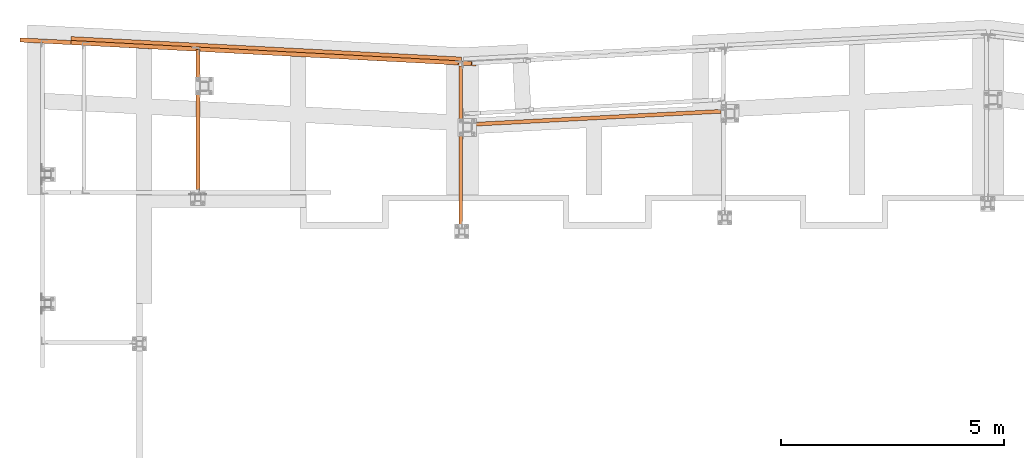
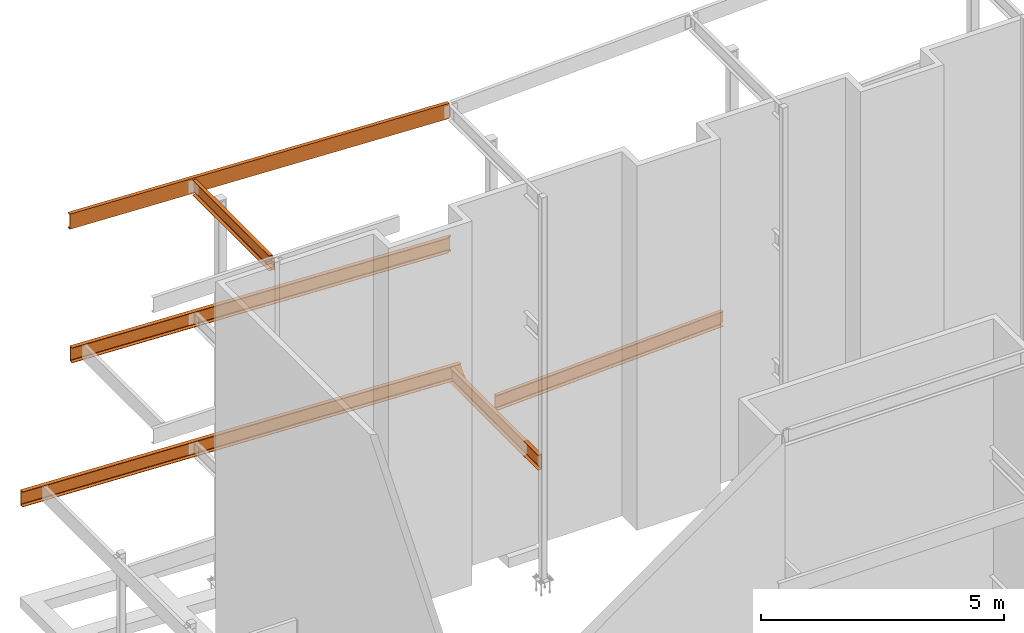
# One storey, part 14 of 89: 6 proxies.
"""IFC4 building model written with IfcOpenShell, lengths in feet."""

from ifc_helpers import new_model, entity, si_unit, converted_unit, derived_unit, direction, frame, origin, place, context, subcontext, project, spatial, faceted_brep, source, transform, mapped, material, constituent, constituent_set, type_object, type_shapes, element, save


model = new_model("IFC4")

# Units and contexts
model_context = context("Model", 3, precision=0.0001, world=origin(), true_north=direction((6.12303176911189e-17, 1.0)))
body_context = subcontext(model_context, "Body", "Model", "MODEL_VIEW")
ifc_project = project(units=[converted_unit("LENGTHUNIT", "FOOT", entity("IfcRatioMeasure", 0.3048), si_unit("LENGTHUNIT", "METRE"), dimensions=[1, 0, 0, 0, 0, 0, 0]), converted_unit("AREAUNIT", "SQUARE FOOT", entity("IfcRatioMeasure", 0.09290304), si_unit("AREAUNIT", "SQUARE_METRE"), dimensions=[2, 0, 0, 0, 0, 0, 0]), converted_unit("VOLUMEUNIT", "CUBIC FOOT", entity("IfcRatioMeasure", 0.028316846592), si_unit("VOLUMEUNIT", "CUBIC_METRE"), dimensions=[3, 0, 0, 0, 0, 0, 0]), si_unit("PLANEANGLEUNIT", "RADIAN"), si_unit("MASSUNIT", "GRAM", prefix="KILO"), derived_unit("MASSDENSITYUNIT", [(si_unit("MASSUNIT", "GRAM", prefix="KILO"), 1), (si_unit("LENGTHUNIT", "METRE"), -3)]), derived_unit("MOMENTOFINERTIAUNIT", [(si_unit("LENGTHUNIT", "METRE"), 4)]), si_unit("TIMEUNIT", "SECOND"), si_unit("FREQUENCYUNIT", "HERTZ"), si_unit("THERMODYNAMICTEMPERATUREUNIT", "DEGREE_CELSIUS"), derived_unit("THERMALTRANSMITTANCEUNIT", [(si_unit("MASSUNIT", "GRAM", prefix="KILO"), 1), (si_unit("THERMODYNAMICTEMPERATUREUNIT", "KELVIN"), -1), (si_unit("TIMEUNIT", "SECOND"), -3)]), derived_unit("VOLUMETRICFLOWRATEUNIT", [(si_unit("LENGTHUNIT", "METRE"), 3), (si_unit("TIMEUNIT", "SECOND"), -1)]), si_unit("ELECTRICCURRENTUNIT", "AMPERE"), si_unit("ELECTRICVOLTAGEUNIT", "VOLT"), si_unit("POWERUNIT", "WATT"), si_unit("FORCEUNIT", "NEWTON"), si_unit("ILLUMINANCEUNIT", "LUX"), si_unit("LUMINOUSFLUXUNIT", "LUMEN"), si_unit("LUMINOUSINTENSITYUNIT", "CANDELA"), derived_unit("USERDEFINED", [(si_unit("MASSUNIT", "GRAM", prefix="KILO"), -1), (si_unit("LENGTHUNIT", "METRE"), -2), (si_unit("TIMEUNIT", "SECOND"), 3), (si_unit("LUMINOUSFLUXUNIT", "LUMEN"), 1)]), derived_unit("LINEARVELOCITYUNIT", [(si_unit("LENGTHUNIT", "METRE"), 1), (si_unit("TIMEUNIT", "SECOND"), -1)]), si_unit("PRESSUREUNIT", "PASCAL"), derived_unit("USERDEFINED", [(si_unit("LENGTHUNIT", "METRE"), -2), (si_unit("MASSUNIT", "GRAM", prefix="KILO"), 1), (si_unit("TIMEUNIT", "SECOND"), -2)]), derived_unit("LINEARFORCEUNIT", [(si_unit("MASSUNIT", "GRAM", prefix="KILO"), 1), (si_unit("LENGTHUNIT", "METRE"), 1), (si_unit("TIMEUNIT", "SECOND"), -2), (si_unit("LENGTHUNIT", "METRE"), -1)]), derived_unit("PLANARFORCEUNIT", [(si_unit("MASSUNIT", "GRAM", prefix="KILO"), 1), (si_unit("LENGTHUNIT", "METRE"), 1), (si_unit("TIMEUNIT", "SECOND"), -2), (si_unit("LENGTHUNIT", "METRE"), -2)])], contexts=[model_context])

# Site, building, storey
site_placement = place(None, origin())
site = spatial("IfcSite", under=ifc_project, at=site_placement, CompositionType="ELEMENT")
building_placement = place(site_placement, frame((-472.238160486, -49.138065117, 0.0)))
building = spatial("IfcBuilding", under=site, at=building_placement, CompositionType="ELEMENT")
storey_placement = place(building_placement, origin())
storey = spatial("IfcBuildingStorey", under=building, at=storey_placement, Name="Level 1", CompositionType="ELEMENT", Elevation=0.0)

# Proxies
ifc_material_1 = material(Name="Color 7720", Category="Materials")
ifc_material_2 = material()
ifc_constituent_1 = constituent(ifc_material_2)
ifc_constituent_2 = constituent(ifc_material_1, Name="Color 7720", Category="Materials")
ifc_constituent_set_1 = constituent_set(constituents=[ifc_constituent_1, ifc_constituent_2])
building_element_proxy_type_1 = type_object("IfcBuildingElementProxyType", Name="B_107", PredefinedType="NOTDEFINED", material=ifc_constituent_set_1)
shared_shape_1 = source(origin(), body_context, "Body", "Brep", [
    faceted_brep([(0.0, 0.282945034847216, 1.25000000000002), (0.0, 0.282945034847216, 0.0), (0.0148285209357937, 0.0, 0.0), (0.0148285209357937, 0.0, 0.0333340558078952), (0.00405689048207591, 0.205534953036704, 0.0676357025785652), (0.00314508419060644, 0.222933253516999, 0.0738152303317055), (0.00240032733219664, 0.2371440609312, 0.0856142600983851), (0.00191364833361263, 0.246430449426384, 0.101590647231966), (0.00174453187503332, 0.249657383688714, 0.119791666666686), (0.00174453187503332, 0.249657383688714, 1.13020833333335), (0.00191364833361263, 0.246430449426384, 1.14840935276807), (0.00240032733219664, 0.2371440609312, 1.16438573990165), (0.00314508419060644, 0.222933253516999, 1.17618476966833), (0.00405689048207591, 0.205534953036704, 1.18236429742147), (0.0148285209357937, 0.0, 1.21666594419214), (0.0148285209357937, 0.0, 1.25000000000002), (18.339448172324, 1.2440747868352, 0.125000000000016), (18.339448172324, 1.2440747868352, 1.12500000000002), (18.3411927041988, 1.2107871356767, 1.12500000000002), (18.3411927041988, 1.2107871356767, 0.125000000000016), (18.219500971703, 1.23778862041752, 0.121828313854659), (18.2060018576239, 1.23708116182627, 0.112796115882787), (18.1969820379655, 1.23660845310837, 0.0992784763485677), (18.1938146985057, 1.236442459881, 0.0833333333333481), (18.1938146985057, 1.23644245988078, 0.0), (18.1938146985056, 1.2364424598843, 1.25000000000002), (18.1938146985056, 1.23644245988407, 1.16666666666668), (18.1969820379653, 1.23660845311133, 1.15072152365147), (18.2060018576237, 1.23708116182911, 1.13720388411724), (18.2195009717029, 1.23778862042025, 1.12817168614538), (18.2354242624537, 1.23862312472738, 1.12500000000002), (18.2354242624539, 1.23862312472465, 0.125000000000018), (18.1989937882445, 0.952991719775582, 0.0), (18.1989937775088, 1.1376197455063, 0.0), (18.1989937882445, 0.952991719775582, 0.0333340558078952), (18.1989937775088, 1.1376197455063, 0.0640621568246242), (18.1978715889875, 1.15903237807242, 0.067635702578583), (18.196959782696, 1.17643067855295, 0.073815230331725), (18.196668108594, 1.19066523102811, 0.0856142600983016), (18.1963589983409, 1.18789432695269, 0.0833333333332433), (18.2004385121993, 1.2001747237689, 0.101590647231944), (18.198966120559, 1.19874990194126, 0.0992784763485552), (18.218201622917, 1.20434144623516, 0.119791666666657), (18.2078113893069, 1.20255324044274, 0.112796115882778), (18.2371687943286, 1.20533547356717, 0.125000000000016), (18.2371687943286, 1.20533547356717, 1.12500000000002), (18.2212455035777, 1.20450096926015, 1.12817168614538), (18.2182016229171, 1.20434144623425, 1.13020833333335), (18.2212455035777, 1.20450096926015, 0.121828313854657), (18.2004385121993, 1.2001747237689, 1.1484093527681), (18.2078113893069, 1.20255324044274, 1.13720388411725), (18.196668108594, 1.19066523102822, 1.16438573990167), (18.198966120559, 1.19874990194126, 1.15072152365148), (18.196959782696, 1.17643067855295, 1.17618476966835), (18.1963589983409, 1.18789432695269, 1.16666666666683), (18.1978715889875, 1.15903237807242, 1.18236429742149), (18.1989937882445, 0.952991719775582, 1.21666594419212), (18.1989937775088, 1.1376197455063, 1.18593784317544), (18.1989937882445, 0.952991719775582, 1.25000000000002), (18.1989937775088, 1.1376197455063, 1.25000000000002)], [[[0, 1, 2, 3, 4, 5, 6, 7, 8, 9, 10, 11, 12, 13, 14, 15]], [[16, 17, 18, 19]], [[20, 21, 22, 23, 24, 1, 0, 25, 26, 27, 28, 29, 30, 17, 16, 31]], [[32, 2, 1, 24, 33]], [[34, 3, 2, 32]], [[35, 36, 4, 3, 34]], [[37, 5, 4, 36]], [[38, 6, 5, 37, 39]], [[40, 7, 6, 38, 41]], [[42, 8, 7, 40, 43]], [[44, 19, 18, 45, 46, 47, 9, 8, 42, 48]], [[49, 10, 9, 47, 50]], [[51, 11, 10, 49, 52]], [[53, 12, 11, 51, 54]], [[55, 13, 12, 53]], [[56, 14, 13, 55, 57]], [[58, 15, 14, 56]], [[59, 25, 0, 15, 58]], [[57, 59, 25, 26, 54, 53, 55]], [[52, 27, 26, 54, 51]], [[50, 28, 27, 52, 49]], [[46, 29, 28, 50, 47]], [[29, 46, 45, 30]], [[17, 30, 45, 18]], [[59, 58, 56, 57]], [[19, 44, 31, 16]], [[48, 20, 31, 44]], [[43, 21, 20, 48, 42]], [[41, 22, 21, 43, 40]], [[39, 23, 22, 41, 38]], [[33, 24, 23, 39, 37, 36, 35]], [[34, 32, 33, 35]]]),
])
type_shapes(building_element_proxy_type_1, [shared_shape_1])
proxy_1_placement = place(building_placement, frame((231.291038536762, 1013.05140014163, 8.35416666666665)))
element("IfcBuildingElementProxy", 1, at=proxy_1_placement, inside=storey, type_object=building_element_proxy_type_1, material=ifc_material_1, Name="B_107:B_107", ObjectType="B_107:B_107", PredefinedType="NOTDEFINED", context=body_context, shape_type="MappedRepresentation", body=[
    mapped(shared_shape_1, transform((0.0, 0.0, 0.0), scale=1.0)),
])
ifc_constituent_3 = constituent(ifc_material_2)
ifc_constituent_4 = constituent(ifc_material_1, Name="Color 7720", Category="Materials")
ifc_constituent_set_2 = constituent_set(constituents=[ifc_constituent_3, ifc_constituent_4])
building_element_proxy_type_2 = type_object("IfcBuildingElementProxyType", Name="25B1", PredefinedType="NOTDEFINED", material=ifc_constituent_set_2)
shared_shape_2 = source(origin(), body_context, "Body", "Brep", [
    faceted_brep([(0.0162241464353201, 2.06671231286009, 1.25), (0.0162241464353201, 2.06671231286009, 0.0), (0.0, 1.75713715708616, 0.0), (0.0, 1.75713715708616, 0.0333062789934004), (0.0107905097204082, 1.96303234799166, 0.0676680457191203), (0.0117017505793626, 1.98041985937664, 0.0738437414016904), (0.012446045596505, 1.9946218543347, 0.0856354543123796), (0.0129324227939946, 2.0039024841218, 0.10160193411237), (0.0131014343794789, 2.00712741728626, 0.11979166666667), (0.0131014343794789, 2.00712741728626, 1.13020833333333), (0.0129324227939946, 2.0039024841218, 1.14839806588763), (0.012446045596505, 1.9946218543347, 1.16436454568762), (0.0117017505793626, 1.98041985937664, 1.17615625859831), (0.0107905097204082, 1.96303234799166, 1.18233195428088), (0.0, 1.75713715708616, 1.2166937210066), (0.0, 1.75713715708616, 1.25), (33.1786171436809, 0.0183195129034175, 1.24999999999983), (33.1879311015114, 0.0178313890571644, 1.21669372100643), (33.2083307316719, 0.22322298729955, 1.18233195428071), (33.2109689792966, 0.240519990095095, 1.17615625859814), (33.2150107761697, 0.25454917030379, 1.16436454568747), (33.2199621108483, 0.263595801584643, 1.14839806588746), (33.225217802996, 0.266554153116999, 1.13020833333318), (33.5077764828886, 0.251745880186945, 0.119791666666794), (33.5126941518654, 0.248254365390039, 0.101601934112509), (33.516672732149, 0.23873973709658, 0.0856354543125182), (33.5192259389879, 0.224364927389274, 0.0738437414018431), (33.5200417048946, 0.206886907414855, 0.0676680457192642), (33.5188603156145, 0.000488123846139388, 0.0333062789935674), (33.5281742734449, 0.0, 0.0), (33.5443984198801, 0.309575155773928, 0.0), (33.1948412901161, 0.327894668677345, 1.2499999999998)], [[[0, 1, 2, 3, 4, 5, 6, 7, 8, 9, 10, 11, 12, 13, 14, 15]], [[16, 17, 18, 19, 20, 21, 22, 23, 24, 25, 26, 27, 28, 29, 30, 31]], [[30, 1, 0, 31]], [[29, 2, 1, 30]], [[28, 3, 2, 29]], [[27, 4, 3, 28]], [[26, 5, 4, 27]], [[25, 6, 5, 26]], [[24, 7, 6, 25]], [[23, 8, 7, 24]], [[22, 9, 8, 23]], [[21, 10, 9, 22]], [[20, 11, 10, 21]], [[19, 12, 11, 20]], [[18, 13, 12, 19]], [[17, 14, 13, 18]], [[16, 15, 14, 17]], [[31, 0, 15, 16]]]),
])
type_shapes(building_element_proxy_type_2, [shared_shape_2])
proxy_2_placement = place(building_placement, frame((197.947317520232, 1017.48537102047, 8.35416666666667)))
element("IfcBuildingElementProxy", 2, at=proxy_2_placement, inside=storey, type_object=building_element_proxy_type_2, material=ifc_material_1, Name="25B1:25B1", ObjectType="25B1:25B1", PredefinedType="NOTDEFINED", context=body_context, shape_type="MappedRepresentation", body=[
    mapped(shared_shape_2, transform((0.0, 0.0, 0.0), scale=1.0)),
])
ifc_constituent_5 = constituent(ifc_material_2)
ifc_constituent_6 = constituent(ifc_material_1, Name="Color 7720", Category="Materials")
ifc_constituent_set_3 = constituent_set(constituents=[ifc_constituent_5, ifc_constituent_6])
building_element_proxy_type_3 = type_object("IfcBuildingElementProxyType", Name="36B1", PredefinedType="NOTDEFINED", material=ifc_constituent_set_3)
shared_shape_3 = source(origin(), body_context, "Body", "Brep", [
    faceted_brep([(0.0162241464371959, 1.80169507490837, 1.25), (0.0162241464371959, 1.80169507490837, 0.0), (0.0, 1.49211991913444, 0.0), (0.0, 1.49211991913444, 0.0333062789934004), (0.010790509722284, 1.69801511003993, 0.0676680457191203), (0.0117017505812385, 1.71540262142491, 0.0738437414016886), (0.0124460455983808, 1.72960461638297, 0.0856354543123814), (0.0129324227958705, 1.73888524617007, 0.10160193411237), (0.0131014343813547, 1.74211017933453, 0.119791666666671), (0.0131014343813547, 1.74211017933453, 1.13020833333333), (0.0129324227958705, 1.73888524617007, 1.14839806588763), (0.0124460455983808, 1.72960461638297, 1.16436454568762), (0.0117017505812385, 1.71540262142491, 1.17615625859831), (0.010790509722284, 1.69801511003993, 1.18233195428088), (0.0, 1.49211991913444, 1.2166937210066), (0.0, 1.49211991913444, 1.25), (28.7172828619411, 0.114994490651156, 0.0), (28.7268232706313, 0.297036332924108, 0.0), (28.7268232706313, 0.297036332924108, 1.25), (28.7172828619411, 0.114994490651156, 1.25), (28.7172828619411, 0.114994490651156, 1.19540973691254), (28.7213896339164, 0.193356368055674, 1.18233195428088), (28.7223008747753, 0.210743879440656, 1.17615625859831), (28.7230451697924, 0.224945874398713, 1.16436454568762), (28.7235315469899, 0.234226504185813, 1.14839806588763), (28.7237005585754, 0.237451437350273, 1.13020833333333), (28.7237005585754, 0.237451437350273, 0.119791666666671), (28.7235315469899, 0.234226504185813, 0.10160193411237), (28.7230451697924, 0.224945874398713, 0.0856354543123814), (28.7223008747753, 0.210743879440656, 0.0738437414016886), (28.7213896339164, 0.193356368055674, 0.0676680457191203), (28.7172828619411, 0.114994490651156, 0.0545902630874586), (28.5035481492094, 0.123019813504925, 0.0), (28.4895763264125, 0.114707452437642, 0.0), (28.4798490481629, 0.101681047076454, 0.0), (28.475847204396, 0.0859237495527623, 0.0), (28.4713441314943, 0.0, 0.0), (28.5196374331875, 0.125352648657554, 0.0), (28.4713441314943, 0.0, 0.0333062789934004), (28.4798490481633, 0.101681047085208, 0.050303491091384), (28.489576326413, 0.114707452446396, 0.0525563528844586), (28.5035481492098, 0.123019813513679, 0.0540616670087068), (28.519637433188, 0.125352648666421, 0.0545902630344379), (28.4758472043965, 0.0859237495615162, 0.0476460594152037), (28.5035481492094, 0.123019813504925, 1.19593833293846), (28.4895763264125, 0.114707452437642, 1.19744364706284), (28.4798490481629, 0.101681047076454, 1.19969650885599), (28.475847204396, 0.0859237495527623, 1.20235394053219), (28.4713441314943, 0.0, 1.2166937210066), (28.5196374331875, 0.125352648657554, 1.1954097369126), (28.4713441314943, 0.0, 1.25), (28.4798490481629, 0.101681047076454, 1.25), (28.4895763264125, 0.114707452437642, 1.25), (28.5035481492094, 0.123019813504925, 1.25), (28.5196374331875, 0.125352648657554, 1.25), (28.475847204396, 0.0859237495527623, 1.25)], [[[0, 1, 2, 3, 4, 5, 6, 7, 8, 9, 10, 11, 12, 13, 14, 15]], [[16, 17, 18, 19, 20, 21, 22, 23, 24, 25, 26, 27, 28, 29, 30, 31]], [[17, 1, 0, 18]], [[32, 33, 34, 35, 36, 2, 1, 17, 16, 37]], [[38, 3, 2, 36]], [[39, 40, 41, 42, 31, 30, 4, 3, 38, 43]], [[29, 5, 4, 30]], [[28, 6, 5, 29]], [[27, 7, 6, 28]], [[26, 8, 7, 27]], [[25, 9, 8, 26]], [[24, 10, 9, 25]], [[23, 11, 10, 24]], [[22, 12, 11, 23]], [[21, 13, 12, 22]], [[44, 45, 46, 47, 48, 14, 13, 21, 20, 49]], [[50, 15, 14, 48]], [[51, 52, 53, 54, 19, 18, 0, 15, 50, 55]], [[19, 54, 49, 20]], [[53, 44, 49, 54]], [[52, 45, 44, 53]], [[51, 46, 45, 52]], [[55, 47, 46, 51]], [[48, 47, 55, 50]], [[42, 37, 16, 31]], [[32, 37, 42, 41]], [[33, 32, 41, 40]], [[34, 33, 40, 39]], [[35, 34, 39, 43]], [[35, 43, 38, 36]]]),
])
type_shapes(building_element_proxy_type_3, [shared_shape_3])
proxy_3_placement = place(building_placement, frame((201.691435842214, 1017.55475508086, 19.0208333333333)))
element("IfcBuildingElementProxy", 3, at=proxy_3_placement, inside=storey, type_object=building_element_proxy_type_3, material=ifc_material_1, Name="36B1:36B1", ObjectType="36B1:36B1", PredefinedType="NOTDEFINED", context=body_context, shape_type="MappedRepresentation", body=[
    mapped(shared_shape_3, transform((0.0, 0.0, 0.0), scale=1.0)),
])
ifc_constituent_7 = constituent(ifc_material_2)
ifc_constituent_8 = constituent(ifc_material_1, Name="Color 7720", Category="Materials")
ifc_constituent_set_4 = constituent_set(constituents=[ifc_constituent_7, ifc_constituent_8])
building_element_proxy_type_4 = type_object("IfcBuildingElementProxyType", Name="42B1", PredefinedType="NOTDEFINED", material=ifc_constituent_set_4)
shared_shape_4 = source(origin(), body_context, "Body", "Brep", [
    faceted_brep([(0.014828520935481, 1.78749139130673, 1.25), (0.014828520935481, 1.78749139130673, 1.21666594419212), (0.00405689048182012, 1.58195643827025, 1.18236429742145), (0.00314508419035064, 1.56455813778985, 1.17618476966831), (0.00240032733196927, 1.55034733037576, 1.16438573990163), (0.00191364833335683, 1.54106094188057, 1.14840935276805), (0.00174453187477752, 1.53783400761824, 1.13020833333333), (0.00174453187477752, 1.53783400761824, 0.119791666666671), (0.00191364833335683, 1.54106094188057, 0.101590647231951), (0.00240032733196927, 1.55034733037576, 0.0856142600983709), (0.00314508419035064, 1.56455813778985, 0.0738152303316895), (0.00405689048182012, 1.58195643827025, 0.0676357025785492), (0.014828520935481, 1.78749139130673, 0.033334055807881), (0.014828520935481, 1.78749139130673, 0.0), (0.0, 1.50454635645974, 0.0), (0.0, 1.50454635645974, 1.25), (28.7084546806412, 0.0, 1.25), (28.7084546806412, 0.0, 0.0), (28.7084546806413, 0.28372216469927, 0.0), (28.7084546806413, 0.28372216469927, 0.033334055807881), (28.7084546806413, 0.0776226944315113, 0.0676357025785492), (28.7084546806413, 0.0601766082081667, 0.0738152303316895), (28.7084546806413, 0.0459267697409587, 0.0856142600983709), (28.7084546806413, 0.036614875480268, 0.101590647231951), (28.7084546806413, 0.0333790781998005, 0.119791666666671), (28.7084546806413, 0.0333790781998005, 1.13020833333333), (28.7084546806413, 0.036614875480268, 1.14840935276805), (28.7084546806413, 0.0459267697409587, 1.16438573990163), (28.7084546806413, 0.0601766082081667, 1.17618476966831), (28.7084546806413, 0.0776226944315113, 1.18236429742145), (28.7084546806413, 0.28372216469927, 1.21666594419212), (28.7084546806413, 0.28372216469927, 1.25)], [[[0, 1, 2, 3, 4, 5, 6, 7, 8, 9, 10, 11, 12, 13, 14, 15]], [[16, 17, 18, 19, 20, 21, 22, 23, 24, 25, 26, 27, 28, 29, 30, 31]], [[30, 1, 0, 31]], [[29, 2, 1, 30]], [[28, 3, 2, 29]], [[27, 4, 3, 28]], [[26, 5, 4, 27]], [[25, 6, 5, 26]], [[24, 7, 6, 25]], [[23, 8, 7, 24]], [[22, 9, 8, 23]], [[21, 10, 9, 22]], [[20, 11, 10, 21]], [[19, 12, 11, 20]], [[18, 13, 12, 19]], [[17, 14, 13, 18]], [[16, 15, 14, 17]], [[31, 0, 15, 16]]]),
])
type_shapes(building_element_proxy_type_4, [shared_shape_4])
proxy_4_placement = place(building_placement, frame((201.697923804506, 1017.85510122665, 29.8333333333333)))
element("IfcBuildingElementProxy", 4, at=proxy_4_placement, inside=storey, type_object=building_element_proxy_type_4, material=ifc_material_1, Name="42B1:42B1", ObjectType="42B1:42B1", PredefinedType="NOTDEFINED", context=body_context, shape_type="MappedRepresentation", body=[
    mapped(shared_shape_4, transform((0.0, 0.0, 0.0), scale=1.0)),
])
ifc_constituent_9 = constituent(ifc_material_2)
ifc_constituent_10 = constituent(ifc_material_1, Name="Color 7720", Category="Materials")
ifc_constituent_set_5 = constituent_set(constituents=[ifc_constituent_9, ifc_constituent_10])
building_element_proxy_type_5 = type_object("IfcBuildingElementProxyType", Name="c736", PredefinedType="NOTDEFINED", material=ifc_constituent_set_5)
shared_shape_5 = source(origin(), body_context, "Body", "Brep", [
    faceted_brep([(0.0, 0.0, 1.25), (0.0, 0.0, 1.21666594419212), (0.205817018106757, 0.0, 1.18236429742145), (0.223239195075223, 0.0, 1.17618476966831), (0.237469504634021, 0.0, 1.16438573990164), (0.24676863726728, 0.0, 1.14840935276805), (0.25, 0.0, 1.13020833333333), (0.25, 0.0, 0.119791666666671), (0.24676863726728, 0.0, 0.101590647231951), (0.237469504634021, 0.0, 0.0856142600983709), (0.223239195075223, 0.0, 0.0738152303316912), (0.205817018106757, 0.0, 0.067635702578551), (0.0, 0.0, 0.033334055807881), (0.0, 0.0, 0.0), (0.283333333333331, 0.0, 0.0), (0.283333333333331, 0.0, 1.25), (0.25, 12.0396281418323, 1.125), (0.283333333333331, 12.0396281418323, 1.125), (0.283333333333331, 12.0396281418323, 0.125000000000002), (0.25, 12.0396281418323, 0.125000000000002), (0.0, 11.893794808499, 1.21666594419212), (0.0, 11.893794808499, 1.25), (0.205817018106757, 11.893794808499, 1.18236429742146), (0.208250000000021, 11.893794808499, 1.18150133528076), (0.223239195075223, 11.893794808499, 1.17618476966831), (0.234718575567058, 11.893794808499, 1.16666666666667), (0.237469504634021, 11.8942485130416, 1.16438573990165), (0.245422827132899, 11.8969664946443, 1.15072152365146), (0.246768637267309, 11.898511437836, 1.14840935276806), (0.248758027693015, 11.9059986926163, 1.13720388411724), (0.250000000000057, 11.9164682742323, 1.13020833333334), (0.250000000000028, 11.9195163321505, 0.121828313854643), (0.250000000000028, 11.9164682742323, 0.119791666666671), (0.250000000000028, 11.9195163321505, 1.12817168614536), (0.250000000000028, 11.9354614751657, 1.125), (0.250000000000028, 11.9354614751657, 0.125000000000002), (0.248758027693015, 11.9059986926163, 0.112796115882764), (0.246768637267337, 11.898511437836, 0.101590647231944), (0.245422827132899, 11.8969664946443, 0.0992784763485517), (0.237469504634049, 11.8942485130416, 0.0856142600983674), (0.234718575567058, 11.893794808499, 0.0833333333333321), (0.223239195075223, 11.893794808499, 0.0738152303316717), (0.205817018106757, 11.893794808499, 0.067635702578551), (0.208250000000021, 11.893794808499, 0.0684986647192467), (0.0, 11.893794808499, 0.033334055807881), (0.0, 11.893794808499, 0.0), (0.208250000000021, 11.893794808499, 0.0), (0.283333333333331, 11.893794808499, 0.0), (0.283333333333331, 11.8969664946443, 0.0992784763485499), (0.283333333333331, 11.9059986926163, 0.11279611588277), (0.283333333333331, 11.9195163321505, 0.121828313854641), (0.283333333333331, 11.9354614751657, 0.125), (0.283333333333331, 11.9354614751657, 1.125), (0.283333333333331, 11.9195163321505, 1.12817168614536), (0.283333333333331, 11.9059986926163, 1.13720388411723), (0.283333333333331, 11.8969664946443, 1.15072152365145), (0.283333333333331, 11.893794808499, 1.16666666666667), (0.283333333333331, 11.893794808499, 1.25), (0.283333333333331, 11.893794808499, 0.0833333333333304), (0.208250000000021, 11.893794808499, 1.25)], [[[0, 1, 2, 3, 4, 5, 6, 7, 8, 9, 10, 11, 12, 13, 14, 15]], [[16, 17, 18, 19]], [[20, 1, 0, 21]], [[22, 2, 1, 20]], [[23, 24, 3, 2, 22]], [[4, 3, 24, 25, 26]], [[5, 4, 26, 27, 28]], [[6, 5, 28, 29, 30]], [[31, 32, 7, 6, 30, 33, 34, 16, 19, 35]], [[8, 7, 32, 36, 37]], [[9, 8, 37, 38, 39]], [[10, 9, 39, 40, 41]], [[42, 11, 10, 41, 43]], [[44, 12, 11, 42]], [[45, 13, 12, 44]], [[46, 47, 14, 13, 45]], [[48, 49, 50, 51, 18, 17, 52, 53, 54, 55, 56, 57, 15, 14, 47, 58]], [[21, 0, 15, 57, 59]], [[57, 56, 25, 24, 23, 22, 20, 21, 59]], [[56, 55, 27, 26, 25]], [[55, 54, 29, 28, 27]], [[54, 53, 33, 30, 29]], [[53, 52, 34, 33]], [[34, 52, 17, 16]], [[51, 35, 19, 18]], [[31, 35, 51, 50]], [[50, 49, 36, 32, 31]], [[49, 48, 38, 37, 36]], [[48, 58, 40, 39, 38]], [[44, 45, 46, 47, 58, 40, 41, 43, 42]]]),
])
type_shapes(building_element_proxy_type_5, [shared_shape_5])
proxy_5_placement = place(building_placement, frame((230.216666666667, 1005.58333333333, 8.35416666666667)))
element("IfcBuildingElementProxy", 5, at=proxy_5_placement, inside=storey, type_object=building_element_proxy_type_5, material=ifc_material_1, Name="c736:c736", ObjectType="c736:c736", PredefinedType="NOTDEFINED", context=body_context, shape_type="MappedRepresentation", body=[
    mapped(shared_shape_5, transform((0.0, 0.0, 0.0), scale=1.0)),
])
ifc_constituent_11 = constituent(ifc_material_2)
ifc_constituent_12 = constituent(ifc_material_1, Name="Color 7720", Category="Materials")
ifc_constituent_set_6 = constituent_set(constituents=[ifc_constituent_11, ifc_constituent_12])
building_element_proxy_type_6 = type_object("IfcBuildingElementProxyType", Name="c713", PredefinedType="NOTDEFINED", material=ifc_constituent_set_6)
shared_shape_6 = source(origin(), body_context, "Body", "Brep", [
    faceted_brep([(0.283333333333303, 0.0, 0.125000000000011), (0.283333333333303, 0.0, 1.12500000000001), (0.249999999999972, 0.0, 1.12500000000001), (0.249999999999972, 0.0, 0.125000000000011), (0.283333333333303, 10.5821617970973, 1.25000000000001), (0.283333333333303, 10.5821617970973, 0.0), (0.0, 10.5821617970973, 0.0), (0.0, 10.5821617970973, 0.0333340558078916), (0.205817018106728, 10.5821617970973, 0.0676357025785599), (0.223239195075195, 10.5821617970973, 0.0738152303317001), (0.237469504633992, 10.5821617970973, 0.0856142600983816), (0.246768637267252, 10.5821617970973, 0.101590647231962), (0.249999999999972, 10.5821617970973, 0.119791666666682), (0.249999999999972, 10.5821617970973, 1.13020833333334), (0.246768637267252, 10.5821617970973, 1.14840935276806), (0.237469504633992, 10.5821617970973, 1.16438573990164), (0.223239195075195, 10.5821617970973, 1.17618476966832), (0.205817018106728, 10.5821617970973, 1.18236429742146), (0.0, 10.5821617970973, 1.21666594419213), (0.0, 10.5821617970973, 1.25000000000001), (0.0, 0.270833333333371, 1.25000000000001), (0.0, 0.270833333333371, 1.21666594419213), (0.205817018106728, 0.270833333333371, 1.18236429742146), (0.223239195075195, 0.270833333333371, 1.17618476966834), (0.208249999999993, 0.270833333333371, 1.18150133528077), (0.237469504634021, 0.270379628790806, 1.16438573990167), (0.23471857556703, 0.270833333333371, 1.1666666666667), (0.24676863726728, 0.266116703996431, 1.14840935276809), (0.245422827132899, 0.267661647187992, 1.15072152365148), (0.25, 0.248159867599952, 1.13020833333335), (0.248758027692958, 0.258629449216073, 1.13720388411724), (0.249999999999972, 0.229166666666742, 0.125000000000011), (0.249999999999972, 0.229166666666742, 1.12500000000001), (0.249999999999972, 0.24511180968193, 1.12817168614538), (0.249999999999972, 0.248159867599952, 0.119791666666682), (0.249999999999972, 0.24511180968193, 0.12182831385465), (0.24676863726728, 0.266116703996431, 0.101590647231959), (0.248758027692958, 0.258629449216073, 0.11279611588278), (0.237469504634021, 0.270379628790806, 0.0856142600983567), (0.245422827132899, 0.267661647187992, 0.0992784763485446), (0.223239195075223, 0.270833333333371, 0.0738152303316788), (0.23471857556703, 0.270833333333371, 0.083333333333325), (0.208249999999993, 0.270833333333371, 0.0684986647192432), (0.205817018106728, 0.270833333333371, 0.0676357025785457), (0.0, 0.270833333333371, 0.0333340558078916), (0.0, 0.270833333333371, 0.0), (0.283333333333303, 0.270833333333371, 0.0), (0.208249999999993, 0.270833333333371, 0.0), (0.283333333333303, 0.24511180968193, 0.12182831385465), (0.283333333333303, 0.258629449216073, 0.11279611588278), (0.283333333333303, 0.267661647187992, 0.0992784763485517), (0.283333333333303, 0.270833333333371, 0.0833333333333393), (0.283333333333303, 0.270833333333371, 1.25000000000001), (0.283333333333303, 0.270833333333371, 1.16666666666668), (0.283333333333303, 0.267661647187992, 1.15072152365147), (0.283333333333303, 0.258629449216073, 1.13720388411724), (0.283333333333303, 0.24511180968193, 1.12817168614538), (0.283333333333303, 0.229166666666742, 1.12500000000001), (0.283333333333303, 0.229166666666742, 0.125000000000011), (0.208249999999993, 0.270833333333371, 1.25000000000001)], [[[0, 1, 2, 3]], [[4, 5, 6, 7, 8, 9, 10, 11, 12, 13, 14, 15, 16, 17, 18, 19]], [[20, 19, 18, 21]], [[21, 18, 17, 22]], [[22, 17, 16, 23, 24]], [[16, 15, 25, 26, 23]], [[15, 14, 27, 28, 25]], [[14, 13, 29, 30, 27]], [[31, 3, 2, 32, 33, 29, 13, 12, 34, 35]], [[12, 11, 36, 37, 34]], [[11, 10, 38, 39, 36]], [[10, 9, 40, 41, 38]], [[42, 40, 9, 8, 43]], [[43, 8, 7, 44]], [[44, 7, 6, 45]], [[45, 6, 5, 46, 47]], [[48, 49, 50, 51, 46, 5, 4, 52, 53, 54, 55, 56, 57, 1, 0, 58]], [[59, 52, 4, 19, 20]], [[32, 2, 1, 57]], [[33, 32, 57, 56]], [[56, 55, 30, 29, 33]], [[55, 54, 28, 27, 30]], [[54, 53, 26, 25, 28]], [[22, 21, 20, 59, 52, 53, 26, 23, 24]], [[44, 45, 47, 46, 51, 41, 40, 42, 43]], [[51, 50, 39, 38, 41]], [[50, 49, 37, 36, 39]], [[49, 48, 35, 34, 37]], [[48, 58, 31, 35]], [[58, 0, 3, 31]]]),
])
type_shapes(building_element_proxy_type_6, [shared_shape_6])
proxy_6_placement = place(building_placement, frame((210.883333333334, 1008.11458333334, 29.8333333333333)))
element("IfcBuildingElementProxy", 6, at=proxy_6_placement, inside=storey, type_object=building_element_proxy_type_6, material=ifc_material_1, Name="c713:c713", ObjectType="c713:c713", PredefinedType="NOTDEFINED", context=body_context, shape_type="MappedRepresentation", body=[
    mapped(shared_shape_6, transform((0.0, 0.0, 0.0), scale=1.0)),
])

save(model, "model.ifc")
